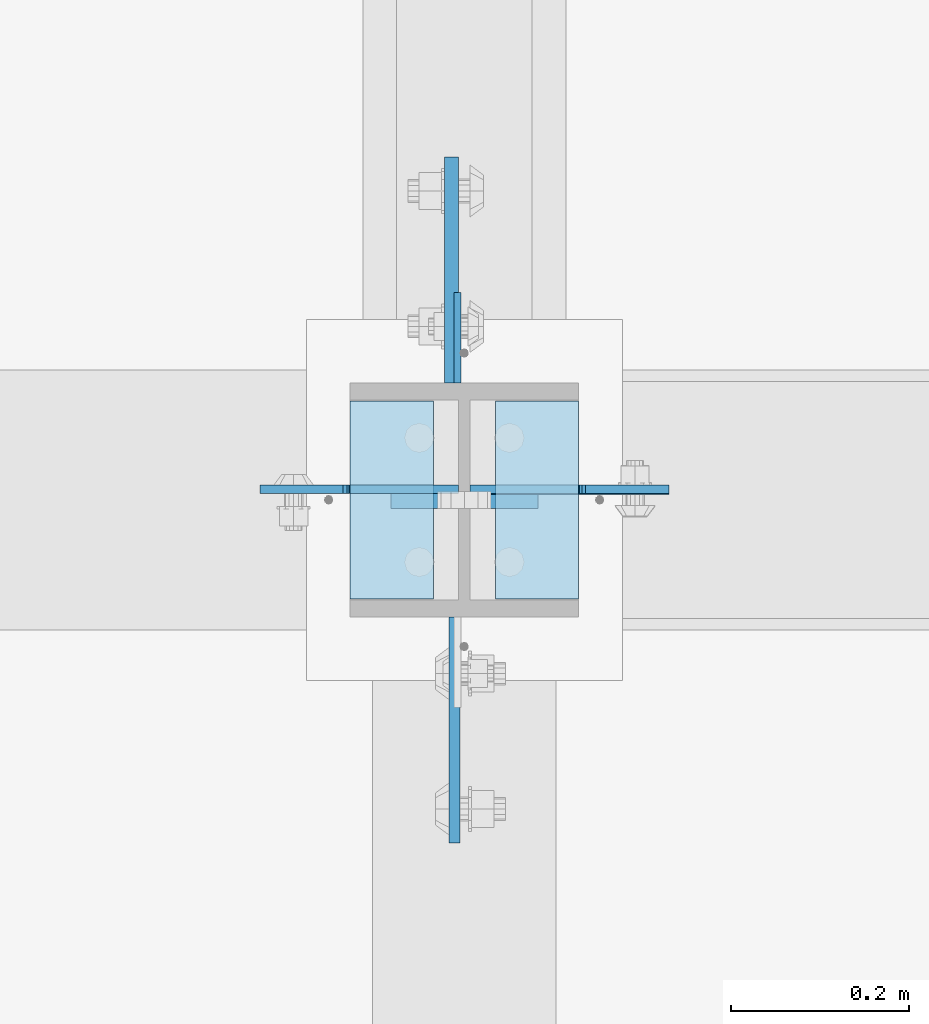
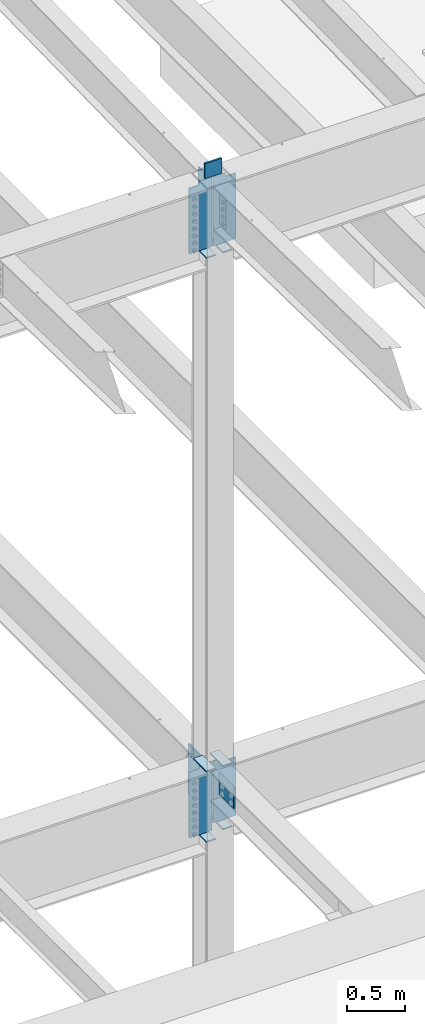
# One storey, part 1523 of 1763: 14 plates, 1 element without a shape of its own.
"""IFC2X3 building model written with IfcOpenShell, lengths in millimetres."""

from ifc_helpers import new_model, si_unit, frame, origin_with_axes, place, context, subcontext, project, spatial, faceted_brep, material, type_object, element, aggregate, save


model = new_model("IFC2X3")

# Units and contexts
model_context = context("Model", 3, precision=1e-05, world=origin_with_axes())
body_context = subcontext(model_context, "Body", "Model", "MODEL_VIEW")
ifc_project = project(units=[si_unit("LENGTHUNIT", "METRE", prefix="MILLI"), si_unit("AREAUNIT", "SQUARE_METRE"), si_unit("VOLUMEUNIT", "CUBIC_METRE"), si_unit("MASSUNIT", "GRAM", prefix="KILO"), si_unit("TIMEUNIT", "SECOND"), si_unit("PLANEANGLEUNIT", "RADIAN"), si_unit("SOLIDANGLEUNIT", "STERADIAN"), si_unit("THERMODYNAMICTEMPERATUREUNIT", "DEGREE_CELSIUS"), si_unit("LUMINOUSINTENSITYUNIT", "LUMEN")], contexts=[model_context])

# Site, building, storey
site_placement = place(None, origin_with_axes())
site = spatial("IfcSite", under=ifc_project, at=site_placement, CompositionType="ELEMENT")
building_placement = place(site_placement, origin_with_axes())
building = spatial("IfcBuilding", under=site, at=building_placement, Name="Undefined", CompositionType="ELEMENT")
storey_placement = place(building_placement, origin_with_axes())
storey = spatial("IfcBuildingStorey", under=building, at=storey_placement, Name="Undefined", CompositionType="ELEMENT", Elevation=0.0)

# Assembly, plates
assembly_placement = place(storey_placement, origin_with_axes())
assembly = element("IfcElementAssembly", 1, at=assembly_placement, inside=storey, Name="COLUMN", AssemblyPlace="NOTDEFINED", PredefinedType="RIGID_FRAME")
ifc_material_1 = material(Name="STEEL/A36")
plate_type_1 = type_object("IfcPlateType", PredefinedType="NOTDEFINED")
plate_1_placement = place(assembly_placement, frame((-72498.9750236984, 30154.5624999999, 11256.2236063032), z_axis=(0.0, 1.0, 0.0), x_axis=(0.0, 0.0, -1.0)))
plate_1 = element("IfcPlate", 2, at=plate_1_placement, type_object=plate_type_1, material=ifc_material_1, Name="PLATE", context=body_context, shape_type="Brep", body=[
    faceted_brep([(0.0, -3.96900000000096, 0.0), (-1.18234311230481e-11, -3.96900000000096, 101.599998474121), (-1.18234311230481e-11, 3.96900000000096, 101.599998474121), (0.0, 3.96900000000096, 0.0), (381.0, -3.96899999999732, 101.599998474121), (381.0, 3.96899999999732, 101.599998474121), (381.0, -3.96900000001915, 3.34694050252438e-10), (381.0, 3.9690000000046, 3.20142135024071e-10)], [[[0, 1, 2, 3]], [[1, 4, 5, 2]], [[4, 6, 7, 5]], [[6, 0, 3, 7]], [[5, 7, 3, 2]], [[6, 4, 1, 0]]]),
])
ifc_material_2 = material(Name="STEEL/A572-50")
plate_type_2 = type_object("IfcPlateType", PredefinedType="NOTDEFINED")
plate_2_placement = place(assembly_placement, frame((-72408.4872721725, 30022.8000001452, 11455.3999938917), z_axis=(0.0, 0.0, -1.0), x_axis=(-1.0, 0.0, 0.0)))
plate_2 = element("IfcPlate", 3, at=plate_2_placement, type_object=plate_type_2, material=ifc_material_2, Name="PLATE", context=body_context, shape_type="Brep", body=[
    faceted_brep([(7.27595761418343e-12, 9.52500000000146, 155.574990844727), (-1.45519152283669e-11, 7.27595761418343e-12, 165.099990844727), (165.099990844727, 0.0, 165.099990844727), (165.099990844727, 9.52500000000146, 155.574990844727), (-3.63797880709171e-11, -9.5249999999869, 155.574990844727), (165.099990844727, -9.52500000000146, 155.574990844727), (0.0, 9.52500000000146, 0.0), (0.0, -9.52500000000146, 0.0), (165.099990844727, -9.52500000000146, 0.0), (165.099990844727, 9.52500000000146, 0.0)], [[[0, 1, 2, 3]], [[1, 4, 5, 2]], [[6, 7, 4, 1, 0]], [[5, 8, 9, 3, 2]], [[8, 7, 6, 9]], [[9, 6, 0, 3]], [[7, 8, 5, 4]]]),
])
plate_type_3 = type_object("IfcPlateType", PredefinedType="NOTDEFINED")
plate_3_placement = place(assembly_placement, frame((-72362.4497736983, 29911.675, 10547.2838431128), z_axis=(0.0, 1.0, 0.0), x_axis=(-1.0, 0.0, 0.0)))
plate_3 = element("IfcPlate", 4, at=plate_3_placement, type_object=plate_type_3, material=ifc_material_1, Name="PLATE", context=body_context, shape_type="Brep", body=[
    faceted_brep([(0.0, -6.34999999999491, 1.45519152283669e-11), (0.0, -6.35000000000036, 222.25), (0.0, 6.35000000000036, 222.25), (0.0, 6.34999999999491, -2.91038304567337e-11), (93.6624984741211, -6.35000000000036, 222.25), (93.6624984741211, 6.35000000000036, 222.25), (93.6624984741211, -6.35000000000036, 0.0), (93.6624984741211, 6.35000000000036, 0.0)], [[[0, 1, 2, 3]], [[1, 4, 5, 2]], [[4, 6, 7, 5]], [[6, 0, 3, 7]], [[5, 7, 3, 2]], [[6, 4, 1, 0]]]),
])
plate_4_placement = place(assembly_placement, frame((-72619.6247736983, 30133.925, 10547.2838431128), z_axis=(0.0, -1.0, 0.0), x_axis=(1.0, 0.0, 0.0)))
plate_4 = element("IfcPlate", 5, at=plate_4_placement, type_object=plate_type_3, material=ifc_material_1, Name="PLATE", context=body_context, shape_type="Brep", body=[
    faceted_brep([(0.0, -6.34999999999491, 1.45519152283669e-11), (0.0, -6.35000000000036, 222.25), (0.0, 6.35000000000036, 222.25), (0.0, 6.34999999999491, -2.91038304567337e-11), (93.6624984741211, -6.35000000000036, 222.25), (93.6624984741211, 6.35000000000036, 222.25), (93.6624984741211, -6.35000000000036, 0.0), (93.6624984741211, 6.35000000000036, 0.0)], [[[0, 1, 2, 3]], [[1, 4, 5, 2]], [[4, 6, 7, 5]], [[6, 0, 3, 7]], [[5, 7, 3, 2]], [[6, 4, 1, 0]]]),
])
plate_5_placement = place(assembly_placement, frame((-72619.6247736983, 30133.925, 4451.34997558594), z_axis=(0.0, -1.0, 0.0), x_axis=(1.0, 0.0, 0.0)))
plate_5 = element("IfcPlate", 6, at=plate_5_placement, type_object=plate_type_3, material=ifc_material_1, Name="PLATE", context=body_context, shape_type="Brep", body=[
    faceted_brep([(0.0, -6.34999999999491, 1.45519152283669e-11), (0.0, -6.35000000000036, 222.25), (0.0, 6.35000000000036, 222.25), (0.0, 6.34999999999491, -2.91038304567337e-11), (93.6624984741211, -6.35000000000036, 222.25), (93.6624984741211, 6.35000000000036, 222.25), (93.6624984741211, -6.35000000000036, 0.0), (93.6624984741211, 6.35000000000036, 0.0)], [[[0, 1, 2, 3]], [[1, 4, 5, 2]], [[4, 6, 7, 5]], [[6, 0, 3, 7]], [[5, 7, 3, 2]], [[6, 4, 1, 0]]]),
])
plate_6_placement = place(assembly_placement, frame((-72619.6247736983, 30133.925, 5187.95), z_axis=(0.0, -1.0, 0.0), x_axis=(1.0, 0.0, 0.0)))
plate_6 = element("IfcPlate", 7, at=plate_6_placement, type_object=plate_type_3, material=ifc_material_1, Name="PLATE", context=body_context, shape_type="Brep", body=[
    faceted_brep([(0.0, -6.34999999999491, 1.45519152283669e-11), (0.0, -6.35000000000036, 222.25), (0.0, 6.35000000000036, 222.25), (0.0, 6.34999999999491, -2.91038304567337e-11), (93.6624984741211, -6.35000000000036, 222.25), (93.6624984741211, 6.35000000000036, 222.25), (93.6624984741211, -6.35000000000036, 0.0), (93.6624984741211, 6.35000000000036, 0.0)], [[[0, 1, 2, 3]], [[1, 4, 5, 2]], [[4, 6, 7, 5]], [[6, 0, 3, 7]], [[5, 7, 3, 2]], [[6, 4, 1, 0]]]),
])
plate_7_placement = place(assembly_placement, frame((-72362.4497736983, 29911.675, 4527.54998779297), z_axis=(0.0, 1.0, 0.0), x_axis=(-1.0, 0.0, 0.0)))
plate_7 = element("IfcPlate", 8, at=plate_7_placement, type_object=plate_type_3, material=ifc_material_1, Name="PLATE", context=body_context, shape_type="Brep", body=[
    faceted_brep([(0.0, -6.34999999999491, 1.45519152283669e-11), (0.0, -6.35000000000036, 222.25), (0.0, 6.35000000000036, 222.25), (0.0, 6.34999999999491, -2.91038304567337e-11), (93.6624984741211, -6.35000000000036, 222.25), (93.6624984741211, 6.35000000000036, 222.25), (93.6624984741211, -6.35000000000036, 0.0), (93.6624984741211, 6.35000000000036, 0.0)], [[[0, 1, 2, 3]], [[1, 4, 5, 2]], [[4, 6, 7, 5]], [[6, 0, 3, 7]], [[5, 7, 3, 2]], [[6, 4, 1, 0]]]),
])
plate_8_placement = place(assembly_placement, frame((-72362.4497736983, 29911.675, 5187.95), z_axis=(0.0, 1.0, 0.0), x_axis=(-1.0, 0.0, 0.0)))
plate_8 = element("IfcPlate", 9, at=plate_8_placement, type_object=plate_type_3, material=ifc_material_1, Name="PLATE", context=body_context, shape_type="Brep", body=[
    faceted_brep([(0.0, -6.34999999999491, 1.45519152283669e-11), (0.0, -6.35000000000036, 222.25), (0.0, 6.35000000000036, 222.25), (0.0, 6.34999999999491, -2.91038304567337e-11), (93.6624984741211, -6.35000000000036, 222.25), (93.6624984741211, 6.35000000000036, 222.25), (93.6624984741211, -6.35000000000036, 0.0), (93.6624984741211, 6.35000000000036, 0.0)], [[[0, 1, 2, 3]], [[1, 4, 5, 2]], [[4, 6, 7, 5]], [[6, 0, 3, 7]], [[5, 7, 3, 2]], [[6, 4, 1, 0]]]),
])
plate_type_4 = type_object("IfcPlateType", PredefinedType="NOTDEFINED")
plate_9_placement = place(assembly_placement, frame((-72502.1497736984, 29891.0375, 5156.2), z_axis=(0.0, -1.0, 0.0), x_axis=(0.0, 0.0, -1.0)))
plate_9 = element("IfcPlate", 10, at=plate_9_placement, type_object=plate_type_4, material=ifc_material_2, Name="PLATE", context=body_context, shape_type="Brep", body=[
    faceted_brep([(0.0, -6.34999999999491, 1.45519152283669e-11), (0.0, -6.34999999999854, 254.0), (0.0, 6.34999999999854, 254.0), (0.0, 6.34999999999491, -2.91038304567337e-11), (228.600006103516, -6.34999999999854, 254.0), (228.600006103516, 6.34999999999854, 254.0), (228.600006103565, -6.34999999936554, -7.49423634260893e-10), (228.600006103557, 6.35000000064611, -7.13043846189976e-10)], [[[0, 1, 2, 3]], [[1, 4, 5, 2]], [[4, 6, 7, 5]], [[6, 0, 3, 7]], [[5, 7, 3, 2]], [[6, 4, 1, 0]]]),
])
plate_type_5 = type_object("IfcPlateType", PredefinedType="NOTDEFINED")
plate_10_placement = place(assembly_placement, frame((-72505.3247736984, 30154.5625, 5143.5), z_axis=(0.0, 1.0, 0.0), x_axis=(0.0, 0.0, -1.0)))
plate_10 = element("IfcPlate", 11, at=plate_10_placement, type_object=plate_type_5, material=ifc_material_2, Name="PLATE", context=body_context, shape_type="Brep", body=[
    faceted_brep([(-7.27595761418343e-12, -7.9375, 0.0), (0.0, -7.9375, 254.0), (0.0, 7.9375, 254.0), (-7.27595761418343e-12, 7.9375, 0.0), (533.400024414062, -7.9375, 254.0), (533.400024414062, 7.9375, 254.0), (533.400024414062, -7.9375, 0.0), (533.400024414062, 7.9375, 0.0)], [[[0, 1, 2, 3]], [[1, 4, 5, 2]], [[4, 6, 7, 5]], [[6, 0, 3, 7]], [[5, 7, 3, 2]], [[6, 4, 1, 0]]]),
])
plate_type_6 = type_object("IfcPlateType", PredefinedType="NOTDEFINED")
plate_11_placement = place(assembly_placement, frame((-72484.6872736983, 30034.7062498557, 11277.5338675269), z_axis=(1.0, 0.0, 0.0), x_axis=(0.0, 0.0, -1.0)))
plate_11 = element("IfcPlate", 12, at=plate_11_placement, type_object=plate_type_6, material=ifc_material_1, Name="PLATE", context=body_context, shape_type="Brep", body=[
    faceted_brep([(25.4000001907334, -4.76250000000073, 122.237503051758), (25.4000001907334, 4.76250000000073, 122.237503051758), (-2.5465851649642e-11, 4.76250000019581, 122.237500000236), (-3.45607986673713e-11, -4.76249999983202, 122.23750000025), (30.2600797087798, -4.76250000000073, 123.204232974349), (30.2600797087798, 4.76250000000073, 123.204232974349), (34.3802561769335, -4.76250000000073, 125.957246874823), (34.3802561769335, 4.76250000000073, 125.957246874823), (37.133270077411, -4.76250000000073, 130.077423342977), (37.133270077411, 4.76250000000073, 130.077423342977), (38.0999999999985, -4.76250000000073, 134.937502861023), (38.0999999999985, 4.76250000000073, 134.937502861023), (38.0999999999985, -4.76250000000073, 223.837493896484), (38.0999999999985, 4.76250000000073, 223.837493896484), (723.900024414062, -4.76250000000073, 0.0), (0.0, -4.76249999999982, 0.0), (0.0, 4.76249999999982, 0.0), (723.900024414062, 4.76250000000073, 0.0), (723.900024414062, -4.76250000000073, 223.837493896484), (723.900024414062, 4.76250000000073, 223.837493896484)], [[[0, 1, 2, 3]], [[4, 5, 1, 0]], [[6, 7, 5, 4]], [[8, 9, 7, 6]], [[10, 11, 9, 8]], [[12, 13, 11, 10]], [[14, 15, 16, 17]], [[18, 14, 17, 19]], [[8, 6, 4, 0, 3, 15, 14, 18, 12, 10]], [[16, 15, 3, 2]], [[19, 17, 16, 2, 1, 5, 7, 9, 11, 13]], [[18, 19, 13, 12]]]),
])
plate_12_placement = place(assembly_placement, frame((-72497.3872736983, 30034.7062498557, 11277.5338675269), z_axis=(-1.0, 0.0, 0.0), x_axis=(0.0, 0.0, -1.0)))
plate_12 = element("IfcPlate", 13, at=plate_12_placement, type_object=plate_type_6, material=ifc_material_1, Name="PLATE", context=body_context, shape_type="Brep", body=[
    faceted_brep([(25.4000001907334, -4.76250000000073, 122.237503051758), (25.4000001907334, 4.76250000000073, 122.237503051758), (-2.5465851649642e-11, 4.76250000019581, 122.237500000236), (-3.45607986673713e-11, -4.76249999983202, 122.23750000025), (30.2600797087798, -4.76250000000073, 123.204232974349), (30.2600797087798, 4.76250000000073, 123.204232974349), (34.3802561769335, -4.76250000000073, 125.957246874823), (34.3802561769335, 4.76250000000073, 125.957246874823), (37.133270077411, -4.76250000000073, 130.077423342977), (37.133270077411, 4.76250000000073, 130.077423342977), (38.0999999999985, -4.76250000000073, 134.937502861023), (38.0999999999985, 4.76250000000073, 134.937502861023), (38.0999999999985, -4.76250000000073, 223.837493896484), (38.0999999999985, 4.76250000000073, 223.837493896484), (723.900024414062, -4.76250000000073, 0.0), (0.0, -4.76249999999982, 0.0), (0.0, 4.76249999999982, 0.0), (723.900024414062, 4.76250000000073, 0.0), (723.900024414062, -4.76250000000073, 223.837493896484), (723.900024414062, 4.76250000000073, 223.837493896484)], [[[0, 1, 2, 3]], [[4, 5, 1, 0]], [[6, 7, 5, 4]], [[8, 9, 7, 6]], [[10, 11, 9, 8]], [[12, 13, 11, 10]], [[14, 15, 16, 17]], [[18, 14, 17, 19]], [[8, 6, 4, 0, 3, 15, 14, 18, 12, 10]], [[16, 15, 3, 2]], [[19, 17, 16, 2, 1, 5, 7, 9, 11, 13]], [[18, 19, 13, 12]]]),
])
plate_13_placement = place(assembly_placement, frame((-72497.3872736983, 30034.70625, 5181.6), z_axis=(-1.0, 0.0, 0.0), x_axis=(0.0, 0.0, -1.0)))
plate_13 = element("IfcPlate", 14, at=plate_13_placement, type_object=plate_type_6, material=ifc_material_1, Name="PLATE", context=body_context, shape_type="Brep", body=[
    faceted_brep([(25.4000001907334, -4.76250000000073, 122.237503051758), (25.4000001907334, 4.76250000000073, 122.237503051758), (-2.5465851649642e-11, 4.76250000019581, 122.237500000236), (-3.45607986673713e-11, -4.76249999983202, 122.23750000025), (30.2600797087798, -4.76250000000073, 123.204232974349), (30.2600797087798, 4.76250000000073, 123.204232974349), (34.3802561769335, -4.76250000000073, 125.957246874823), (34.3802561769335, 4.76250000000073, 125.957246874823), (37.133270077411, -4.76250000000073, 130.077423342977), (37.133270077411, 4.76250000000073, 130.077423342977), (38.0999999999985, -4.76250000000073, 134.937502861023), (38.0999999999985, 4.76250000000073, 134.937502861023), (38.0999999999985, -4.76250000000073, 223.837493896484), (38.0999999999985, 4.76250000000073, 223.837493896484), (723.900024414062, -4.76250000000073, 0.0), (0.0, -4.76249999999982, 0.0), (0.0, 4.76249999999982, 0.0), (723.900024414062, 4.76250000000073, 0.0), (723.900024414062, -4.76250000000073, 223.837493896484), (723.900024414062, 4.76250000000073, 223.837493896484)], [[[0, 1, 2, 3]], [[4, 5, 1, 0]], [[6, 7, 5, 4]], [[8, 9, 7, 6]], [[10, 11, 9, 8]], [[12, 13, 11, 10]], [[14, 15, 16, 17]], [[18, 14, 17, 19]], [[8, 6, 4, 0, 3, 15, 14, 18, 12, 10]], [[16, 15, 3, 2]], [[19, 17, 16, 2, 1, 5, 7, 9, 11, 13]], [[18, 19, 13, 12]]]),
])
plate_14_placement = place(assembly_placement, frame((-72484.6872736983, 30033.9125, 5181.6), z_axis=(1.0, 0.0, 0.0), x_axis=(0.0, 0.0, -1.0)))
plate_14 = element("IfcPlate", 15, at=plate_14_placement, type_object=plate_type_6, material=ifc_material_1, Name="PLATE", context=body_context, shape_type="Brep", body=[
    faceted_brep([(25.4000001907334, -4.76250000000073, 122.237503051758), (25.4000001907334, 4.76250000000073, 122.237503051758), (-2.5465851649642e-11, 4.76250000019581, 122.237500000236), (-3.45607986673713e-11, -4.76249999983202, 122.23750000025), (30.2600797087798, -4.76250000000073, 123.204232974349), (30.2600797087798, 4.76250000000073, 123.204232974349), (34.3802561769335, -4.76250000000073, 125.957246874823), (34.3802561769335, 4.76250000000073, 125.957246874823), (37.133270077411, -4.76250000000073, 130.077423342977), (37.133270077411, 4.76250000000073, 130.077423342977), (38.0999999999985, -4.76250000000073, 134.937502861023), (38.0999999999985, 4.76250000000073, 134.937502861023), (38.0999999999985, -4.76250000000073, 223.837493896484), (38.0999999999985, 4.76250000000073, 223.837493896484), (647.700012207031, -4.76250000000073, 0.0), (0.0, -4.76249999999982, 0.0), (0.0, 4.76249999999982, 0.0), (647.700012207031, 4.76250000000073, 0.0), (647.700012207031, -4.76250000000073, 223.837493896484), (647.700012207031, 4.76250000000073, 223.837493896484)], [[[0, 1, 2, 3]], [[4, 5, 1, 0]], [[6, 7, 5, 4]], [[8, 9, 7, 6]], [[10, 11, 9, 8]], [[12, 13, 11, 10]], [[14, 15, 16, 17]], [[18, 14, 17, 19]], [[8, 6, 4, 0, 3, 15, 14, 18, 12, 10]], [[16, 15, 3, 2]], [[19, 17, 16, 2, 1, 5, 7, 9, 11, 13]], [[18, 19, 13, 12]]]),
])
aggregate(assembly, [plate_2, plate_3, plate_11, plate_4, plate_12, plate_1, plate_5, plate_6, plate_13, plate_7, plate_8, plate_14, plate_9, plate_10])

save(model, "model.ifc")
